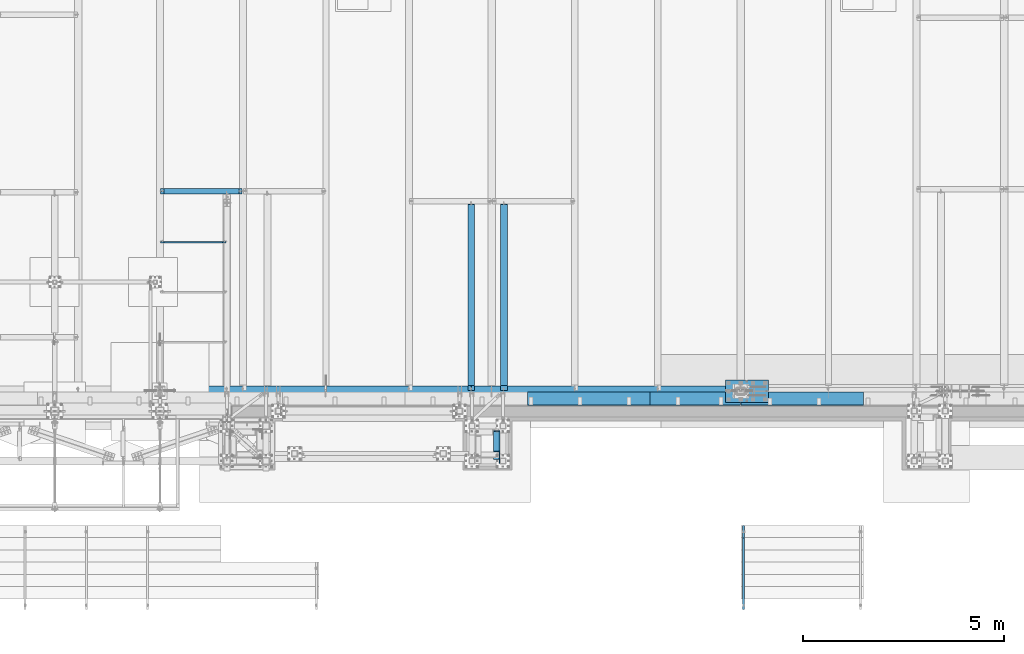
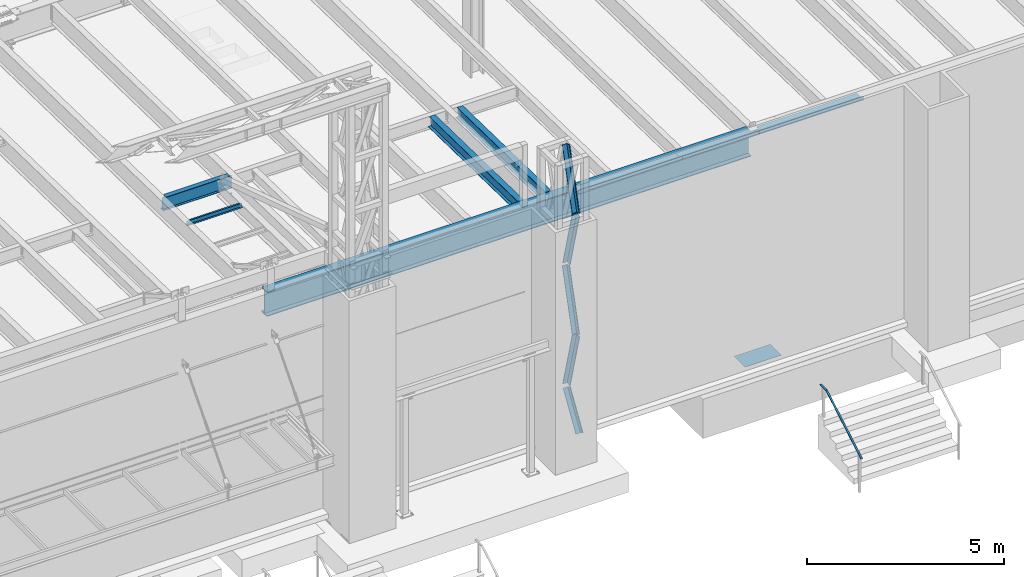
# One storey, part 1065 of 1763: 10 beams, 5 members, 9 elements without a shape of their own.
"""IFC2X3 building model written with IfcOpenShell, lengths in millimetres."""

from ifc_helpers import new_model, si_unit, frame, origin_with_axes, place, context, subcontext, project, spatial, faceted_brep, material, type_object, element, aggregate, save


model = new_model("IFC2X3")

# Units and contexts
model_context = context("Model", 3, precision=1e-05, world=origin_with_axes())
body_context = subcontext(model_context, "Body", "Model", "MODEL_VIEW")
ifc_project = project(units=[si_unit("LENGTHUNIT", "METRE", prefix="MILLI"), si_unit("AREAUNIT", "SQUARE_METRE"), si_unit("VOLUMEUNIT", "CUBIC_METRE"), si_unit("MASSUNIT", "GRAM", prefix="KILO"), si_unit("TIMEUNIT", "SECOND"), si_unit("PLANEANGLEUNIT", "RADIAN"), si_unit("SOLIDANGLEUNIT", "STERADIAN"), si_unit("THERMODYNAMICTEMPERATUREUNIT", "DEGREE_CELSIUS"), si_unit("LUMINOUSINTENSITYUNIT", "LUMEN")], contexts=[model_context])

# Site, building, storey
site_placement = place(None, origin_with_axes())
site = spatial("IfcSite", under=ifc_project, at=site_placement, CompositionType="ELEMENT")
building_placement = place(site_placement, origin_with_axes())
building = spatial("IfcBuilding", under=site, at=building_placement, Name="Undefined", CompositionType="ELEMENT")
storey_placement = place(building_placement, origin_with_axes())
storey = spatial("IfcBuildingStorey", under=building, at=storey_placement, Name="Undefined", CompositionType="ELEMENT", Elevation=0.0)

# Assembly, members
assembly_1_placement = place(storey_placement, origin_with_axes())
assembly_1 = element("IfcElementAssembly", 1, at=assembly_1_placement, inside=storey, Name="FRAME", AssemblyPlace="NOTDEFINED", PredefinedType="RIGID_FRAME")
ifc_material_1 = material(Name="STEEL/A36")
member_type = type_object("IfcMemberType", Name="L6X6X7/8", PredefinedType="NOTDEFINED")
member_1_placement = place(assembly_1_placement, frame((-41020.4383006159, -14787.0004435878, 10758.1513109615), z_axis=(-1.0, 0.0, 0.0), x_axis=(0.0, -0.25744609400632, 0.966292662023721)))
member_1 = element("IfcMember", 2, at=member_1_placement, type_object=member_type, material=ifc_material_1, Name="V. BRACE", ObjectType="L6X6X7/8", context=body_context, shape_type="Brep", body=[
    faceted_brep([(9.09494701772928e-13, -76.2000000000007, -76.2000000000844), (9.09494701772928e-13, 76.2000000000007, -76.2000000000844), (1868.75344729561, 76.1999999999971, -76.1999999992731), (1868.75344729561, -76.1999999999971, -76.1999999992731), (1.81898940354586e-12, -76.2000000000007, -53.9750000000604), (1.81898940354586e-12, 53.9750000000004, -53.9750000000604), (0.0, 53.9750000000004, 76.2000000000771), (0.0, 76.2000000000007, 76.2000000000771), (1868.7534472956, -76.1999999999971, -53.9749999992673), (1868.7534472956, 53.9750000000058, -53.9749999992673), (1868.75344729555, 53.9750000000058, 76.2000000007865), (1868.75344729555, 76.1999999999971, 76.2000000007865)], [[[0, 1, 2, 3]], [[0, 4, 5, 6, 7, 1]], [[5, 4, 8, 9]], [[6, 5, 9, 10]], [[7, 6, 10, 11]], [[1, 7, 11, 2]], [[10, 9, 8, 3, 2, 11]], [[4, 0, 3, 8]]]),
])
member_2_placement = place(assembly_1_placement, frame((-41020.4383006193, -15268.2601858948, 12613.6591825804), z_axis=(-1.0, 0.0, 0.0), x_axis=(0.0, 0.266418265103921, 0.963857514375967)))
member_2 = element("IfcMember", 3, at=member_2_placement, type_object=member_type, material=ifc_material_1, Name="V. BRACE", ObjectType="L6X6X7/8", context=body_context, shape_type="Brep", body=[
    faceted_brep([(9.09494701772928e-13, -76.2000000000007, -76.2000000000844), (9.09494701772928e-13, 76.2000000000007, -76.2000000000844), (1892.74960718638, 76.1999999999971, -76.2000000004191), (1892.74960718638, -76.1999999999971, -76.2000000004191), (1.81898940354586e-12, -76.2000000000007, -53.9750000000604), (1.81898940354586e-12, 53.9750000000004, -53.9750000000604), (0.0, 53.9750000000004, 76.2000000000771), (0.0, 76.2000000000007, 76.2000000000771), (1892.74960718638, -76.1999999999971, -53.9750000004096), (1892.74960718638, 53.9750000000058, -53.9750000004096), (1892.74960718641, 53.9750000000058, 76.1999999996406), (1892.74960718641, 76.1999999999971, 76.1999999996406)], [[[0, 1, 2, 3]], [[0, 4, 5, 6, 7, 1]], [[5, 4, 8, 9]], [[6, 5, 9, 10]], [[7, 6, 10, 11]], [[1, 7, 11, 2]], [[10, 9, 8, 3, 2, 11]], [[4, 0, 3, 8]]]),
])
member_3_placement = place(assembly_1_placement, frame((-41020.4383006091, -14787.0004435878, 7010.06381096154), z_axis=(-1.0, 0.0, 0.0), x_axis=(0.0, -0.25744609400632, 0.966292662023721)))
member_3 = element("IfcMember", 4, at=member_3_placement, type_object=member_type, material=ifc_material_1, Name="V. BRACE", ObjectType="L6X6X7/8", context=body_context, shape_type="Brep", body=[
    faceted_brep([(9.09494701772928e-13, -76.2000000000007, -76.2000000000844), (9.09494701772928e-13, 76.2000000000007, -76.2000000000844), (1868.75344729561, 76.1999999999971, -76.1999999992731), (1868.75344729561, -76.1999999999971, -76.1999999992731), (1.81898940354586e-12, -76.2000000000007, -53.9750000000604), (1.81898940354586e-12, 53.9750000000004, -53.9750000000604), (0.0, 53.9750000000004, 76.2000000000771), (0.0, 76.2000000000007, 76.2000000000771), (1868.7534472956, -76.1999999999971, -53.9749999992673), (1868.7534472956, 53.9750000000058, -53.9749999992673), (1868.75344729555, 53.9750000000058, 76.2000000007865), (1868.75344729555, 76.1999999999971, 76.2000000007865)], [[[0, 1, 2, 3]], [[0, 4, 5, 6, 7, 1]], [[5, 4, 8, 9]], [[6, 5, 9, 10]], [[7, 6, 10, 11]], [[1, 7, 11, 2]], [[10, 9, 8, 3, 2, 11]], [[4, 0, 3, 8]]]),
])
member_4_placement = place(assembly_1_placement, frame((-41020.4384470911, -15452.6556024423, 5905.50000000773), z_axis=(-1.0, 0.0, 0.0), x_axis=(1.18999999498545e-07, 0.53163042301006, 0.846976442016028)))
member_4 = element("IfcMember", 5, at=member_4_placement, type_object=member_type, material=ifc_material_1, Name="V. BRACE", ObjectType="L6X6X7/8", context=body_context, shape_type="Brep", body=[
    faceted_brep([(9.09494701772928e-13, -76.2000000000007, -76.2000000000844), (9.09494701772928e-13, 76.2000000000007, -76.2000000000844), (1228.13053531922, 76.1999999928375, -76.2000000008793), (1228.1305353191, -76.2000000071712, -76.2000000007974), (1.81898940354586e-12, -76.2000000000007, -53.9750000000604), (1.81898940354586e-12, 53.9750000000004, -53.9750000000604), (0.0, 53.9750000000004, 76.2000000000771), (0.0, 76.2000000000007, 76.2000000000771), (1228.13053531911, -76.2000000070693, -53.9750000008135), (1228.13053531921, 53.9749999929481, -53.9750000008862), (1228.13053531927, 53.9749999934866, 76.1999999990185), (1228.13053531929, 76.1999999934924, 76.1999999990057)], [[[0, 1, 2, 3]], [[0, 4, 5, 6, 7, 1]], [[5, 4, 8, 9]], [[6, 5, 9, 10]], [[7, 6, 10, 11]], [[1, 7, 11, 2]], [[10, 9, 8, 3, 2, 11]], [[4, 0, 3, 8]]]),
])
member_5_placement = place(assembly_1_placement, frame((-41020.4383006125, -15268.2601858948, 8865.57168258042), z_axis=(-1.0, 0.0, 0.0), x_axis=(0.0, 0.266418265103921, 0.963857514375967)))
member_5 = element("IfcMember", 6, at=member_5_placement, type_object=member_type, material=ifc_material_1, Name="V. BRACE", ObjectType="L6X6X7/8", context=body_context, shape_type="Brep", body=[
    faceted_brep([(9.09494701772928e-13, -76.2000000000007, -76.2000000000844), (9.09494701772928e-13, 76.2000000000007, -76.2000000000844), (1892.74960718638, 76.1999999999971, -76.2000000004191), (1892.74960718638, -76.1999999999971, -76.2000000004191), (1.81898940354586e-12, -76.2000000000007, -53.9750000000604), (1.81898940354586e-12, 53.9750000000004, -53.9750000000604), (0.0, 53.9750000000004, 76.2000000000771), (0.0, 76.2000000000007, 76.2000000000771), (1892.74960718638, -76.1999999999971, -53.9750000004096), (1892.74960718638, 53.9750000000058, -53.9750000004096), (1892.74960718641, 53.9750000000058, 76.1999999996406), (1892.74960718641, 76.1999999999971, 76.1999999996406)], [[[0, 1, 2, 3]], [[0, 4, 5, 6, 7, 1]], [[5, 4, 8, 9]], [[6, 5, 9, 10]], [[7, 6, 10, 11]], [[1, 7, 11, 2]], [[10, 9, 8, 3, 2, 11]], [[4, 0, 3, 8]]]),
])
aggregate(assembly_1, [member_1, member_2, member_3, member_4, member_5])

# Assembly, beam
assembly_2_placement = place(storey_placement, origin_with_axes())
assembly_2 = element("IfcElementAssembly", 7, at=assembly_2_placement, inside=storey, Name="CHANNEL", AssemblyPlace="NOTDEFINED", PredefinedType="RIGID_FRAME")
beam_type_1 = type_object("IfcBeamType", Name="C6X8.2", PredefinedType="NOTDEFINED")
beam_1_placement = place(assembly_2_placement, frame((-49402.4372736983, -10007.1940204662, 12050.4660879227), z_axis=(0.0, 0.0, 1.0), x_axis=(1.0, 0.0, 0.0)))
beam_1 = element("IfcBeam", 8, at=beam_1_placement, type_object=beam_type_1, material=ifc_material_1, Name="CHANNEL", ObjectType="C6X8.2", context=body_context, shape_type="Brep", body=[
    faceted_brep([(87.3125001907392, 19.0499999999993, 50.8000000015782), (87.3125001907392, 23.8125, 50.8000000015782), (17.4624999999942, 23.8125, 50.8000000015782), (17.4624999999942, 19.0499999999993, 50.8000000015782), (92.1725797087856, 19.0499999999993, 51.7667299241657), (92.1725797087856, 23.8125, 51.7667299241657), (96.2927561769393, 19.0499999999993, 54.5197438246432), (96.2927561769393, 23.8125, 54.5197438246432), (99.0457700774132, 19.0499999999993, 58.6399202927969), (99.0457700774132, 23.8125, 58.6399202927969), (100.012500000004, 19.0499999999993, 63.4999998108433), (100.012500000004, 23.8125, 63.4999998108433), (100.012500000004, -23.8125, 76.2000000000007), (100.012500000004, 23.8125, 76.2000000000007), (100.012500000004, 19.0499999999993, 65.0887700000003), (100.012500000004, -23.8125, 72.2296624999999), (17.4624999999942, 19.0499999999993, -65.0887700000003), (17.4624999999942, -23.8125, -72.2296624999999), (1648.61752778026, -23.8125, -72.2296624999999), (1648.61752778026, 19.0499999999993, -65.0887700000003), (17.4624999999942, -23.8125, -76.2000000000007), (1648.61752778026, -23.8125, -76.2000000000007), (17.4624999999942, 23.8125, -76.2000000000007), (1648.61752778026, 23.8125, -76.2000000000007), (1648.61752778026, 23.8125, 50.7999999979074), (1648.61752778026, 19.0499999999993, 50.7999999979074), (1572.41752758952, 23.8125, 50.7999999979074), (1572.41752758952, 19.0499999999993, 50.7999999979074), (1567.55744807148, 23.8125, 51.766729920495), (1567.55744807148, 19.0499999999993, 51.766729920495), (1563.43727160332, 23.8125, 54.5197438209725), (1563.43727160332, 19.0499999999993, 54.5197438209725), (1560.68425770285, 23.8125, 58.6399202891262), (1560.68425770285, 19.0499999999993, 58.6399202891262), (1559.71752778026, 23.8125, 63.4999998071726), (1559.71752778026, 19.0499999999993, 63.4999998071726), (1559.71752778026, -23.8125, 76.2000000000007), (1559.71752778026, -23.8125, 72.2296624999999), (1559.71752778026, 19.0499999999993, 65.0887700000003), (1559.71752778026, 23.8125, 76.2000000000007)], [[[0, 1, 2, 3]], [[4, 5, 1, 0]], [[6, 7, 5, 4]], [[8, 9, 7, 6]], [[10, 11, 9, 8]], [[12, 13, 11, 10, 14, 15]], [[16, 17, 18, 19]], [[17, 20, 21, 18]], [[20, 22, 23, 21]], [[19, 18, 21, 23, 24, 25]], [[25, 24, 26, 27]], [[27, 26, 28, 29]], [[29, 28, 30, 31]], [[31, 30, 32, 33]], [[33, 32, 34, 35]], [[36, 37, 38, 35, 34, 39]], [[37, 36, 12, 15]], [[38, 37, 15, 14]], [[8, 6, 4, 0, 3, 16, 19, 25, 27, 29, 31, 33, 35, 38, 14, 10]], [[22, 20, 17, 16, 3, 2]], [[39, 34, 32, 30, 28, 26, 24, 23, 22, 2, 1, 5, 7, 9, 11, 13]], [[36, 39, 13, 12]]]),
])
aggregate(assembly_2, [beam_1])

assembly_3_placement = place(storey_placement, origin_with_axes())
assembly_3 = element("IfcElementAssembly", 9, at=assembly_3_placement, inside=storey, Name="BEAM", AssemblyPlace="NOTDEFINED", PredefinedType="RIGID_FRAME")
ifc_material_2 = material(Name="STEEL/A992")
beam_type_2 = type_object("IfcBeamType", Name="W14X30", PredefinedType="NOTDEFINED")
beam_2_placement = place(assembly_3_placement, frame((-40842.6384959181, -13719.5915461759, 12028.5241025932), z_axis=(0.0, 0.0203812129899107, 0.999792281505043), x_axis=(0.0, 0.999792281505044, -0.0203812129898941)))
beam_2 = element("IfcBeam", 10, at=beam_2_placement, type_object=beam_type_2, material=ifc_material_2, Name="BEAM", ObjectType="W14X30", context=body_context, shape_type="Brep", body=[
    faceted_brep([(4643.22007065006, -85.7249999999985, 176.212500002597), (4643.22007065007, -85.7249999999985, 166.68750000259), (4643.22007065007, -3.17500000000291, 166.68750000259), (4643.22007065008, -3.17500000000291, 156.902501503215), (4643.22007065008, 3.17500000000291, 156.902501503215), (4643.22007065007, 3.17500000000291, 166.68750000259), (4643.22007065007, 85.7249999999985, 166.68750000259), (4643.22007065006, 85.7249999999985, 176.212500002597), (4644.18680057267, -3.17500000000291, 152.042421985161), (4644.18680057267, 3.17500000000291, 152.042421985161), (4646.93981447315, -3.17500000000291, 147.922245517004), (4646.93981447315, 3.17500000000291, 147.922245517004), (4651.05999094131, -3.17500000000291, 145.169231616524), (4651.05999094131, 3.17500000000291, 145.169231616524), (4655.92007045936, -3.17500000000291, 144.202501693939), (4655.92007045936, 3.17500000000291, 144.202501693939), (4710.13043812963, -3.17500000000291, 144.202501693968), (4710.13043812963, 3.17500000000291, 144.202501693968), (151.234261463611, -85.7249999999985, 176.212500000163), (151.234261463611, 85.7249999999985, 176.212500000163), (151.234261463616, 85.7249999999985, 166.687500000158), (151.234261463616, 3.17500000000291, 166.687500000158), (151.234261463636, 3.17500000000291, 131.502497673198), (151.234261463636, -3.17500000000291, 131.502497673198), (151.234261463616, -3.17500000000291, 166.687500000158), (151.234261463616, -85.7249999999985, 166.687500000158), (150.267531541049, 3.17500000000291, 126.642418155145), (150.267531541049, -3.17500000000291, 126.642418155145), (147.514517640569, 3.17500000000291, 122.522241686986), (147.514517640569, -3.17500000000291, 122.522241686986), (143.394341172412, 3.17500000000291, 119.769227786501), (143.394341172412, -3.17500000000291, 119.769227786501), (138.534261654358, 3.17500000000291, 118.802497863908), (138.534261654358, -3.17500000000291, 118.802497863908), (21.8124193891163, 3.17500000000291, 118.802497863844), (21.8124193891163, -3.17500000000291, 118.802497863844), (27.6322607307538, 3.17500000000291, -166.68750000006), (27.6322607307538, 85.7249999999985, -166.68750000006), (27.8264321174702, 85.7249999999985, -176.212500000065), (27.8264321174702, -85.7249999999985, -176.212500000065), (27.6322607307538, -85.7249999999985, -166.68750000006), (27.6322607307538, -3.17500000000291, -166.68750000006), (4716.46806991387, 3.17500000000291, -166.687499997519), (4716.46806991387, 85.7249999999985, -166.687499997519), (4716.66224130059, 85.7249999999985, -176.212499997522), (4716.66224130059, -85.7249999999985, -176.212499997522), (4716.46806991387, -85.7249999999985, -166.687499997519), (4716.46806991387, -3.17500000000291, -166.687499997519)], [[[0, 1, 2, 3, 4, 5, 6, 7]], [[8, 9, 4, 3]], [[10, 11, 9, 8]], [[12, 13, 11, 10]], [[14, 15, 13, 12]], [[16, 17, 15, 14]], [[18, 19, 20, 21, 22, 23, 24, 25]], [[23, 22, 26, 27]], [[27, 26, 28, 29]], [[29, 28, 30, 31]], [[31, 30, 32, 33]], [[33, 32, 34, 35]], [[36, 37, 38, 39, 40, 41, 35, 34]], [[37, 36, 42, 43]], [[38, 37, 43, 44]], [[39, 38, 44, 45]], [[40, 39, 45, 46]], [[41, 40, 46, 47]], [[12, 10, 8, 3, 2, 24, 23, 27, 29, 31, 33, 35, 41, 47, 16, 14]], [[25, 24, 2, 1]], [[18, 25, 1, 0]], [[19, 18, 0, 7]], [[20, 19, 7, 6]], [[21, 20, 6, 5]], [[42, 36, 34, 32, 30, 28, 26, 22, 21, 5, 4, 9, 11, 13, 15, 17]], [[47, 46, 45, 44, 43, 42, 17, 16]]]),
])
aggregate(assembly_3, [beam_2])

assembly_4_placement = place(storey_placement, origin_with_axes())
assembly_4 = element("IfcElementAssembly", 11, at=assembly_4_placement, inside=storey, Name="BEAM", AssemblyPlace="NOTDEFINED", PredefinedType="RIGID_FRAME")
beam_3_placement = place(assembly_4_placement, frame((-41655.4384959181, -13719.56444169, 12028.523552142), z_axis=(0.0, 0.0202273960059865, 0.999795405295912), x_axis=(0.0, 0.999795405295912, -0.0202273960060005)))
beam_3 = element("IfcBeam", 12, at=beam_3_placement, type_object=beam_type_2, material=ifc_material_2, Name="BEAM", ObjectType="W14X30", context=body_context, shape_type="Brep", body=[
    faceted_brep([(138.507075903297, -3.17500000000291, 118.802497863813), (138.507075903297, 3.17500000000291, 118.802497863813), (21.8035187866535, 3.17500000000291, 118.802497863793), (21.8035187866535, -3.17500000000291, 118.802497863793), (143.367155421345, -3.17500000000291, 119.769227786404), (143.367155421345, 3.17500000000291, 119.769227786404), (147.487331889499, -3.17500000000291, 122.522241686884), (147.487331889499, 3.17500000000291, 122.522241686884), (150.240345789978, -3.17500000000291, 126.642418155039), (150.240345789978, 3.17500000000291, 126.642418155039), (151.207075712564, -3.17500000000291, 131.502497673087), (151.207075712564, 3.17500000000291, 131.502497673087), (151.207075712555, -85.7249999999985, 176.212500000051), (151.207075712555, 85.7249999999985, 176.212500000051), (151.207075712557, 85.7249999999985, 166.687500000049), (151.207075712557, 3.17500000000291, 166.687500000049), (151.207075712557, -3.17500000000291, 166.687500000049), (151.207075712557, -85.7249999999985, 166.687500000049), (27.5794197479408, -3.17500000000291, -166.687500000011), (27.5794197479408, -85.7249999999985, -166.687500000011), (4716.40057898811, -85.7249999999985, -166.687499999094), (4716.40057898811, -3.17500000000291, -166.687499999094), (27.772125121397, -85.7249999999985, -176.212500000012), (4716.59328436156, -85.7249999999985, -176.212499999096), (27.772125121397, 85.7249999999985, -176.212500000012), (4716.59328436156, 85.7249999999985, -176.212499999096), (27.5794197479408, 85.7249999999985, -166.687500000011), (4716.40057898811, 85.7249999999985, -166.687499999094), (27.5794197479408, 3.17500000000291, -166.687500000011), (4716.40057898811, 3.17500000000291, -166.687499999094), (4710.11079695367, 3.17500000000291, 144.202501684027), (4710.11079695367, -3.17500000000291, 144.202501684027), (4655.87823476279, 3.17500000000291, 144.202501684016), (4655.87823476279, -3.17500000000291, 144.202501684016), (4651.01815524475, 3.17500000000291, 145.169231606602), (4651.01815524475, -3.17500000000291, 145.169231606602), (4646.89797877659, 3.17500000000291, 147.922245507081), (4646.89797877659, -3.17500000000291, 147.922245507081), (4644.14496487611, 3.17500000000291, 152.042421975237), (4644.14496487611, -3.17500000000291, 152.042421975237), (4643.17823495352, 3.17500000000291, 156.902501493283), (4643.17823495352, -3.17500000000291, 156.902501493283), (4643.17823495352, -85.7249999999985, 176.212500000929), (4643.17823495352, -85.7249999999985, 166.687500000928), (4643.17823495352, -3.17500000000291, 166.687500000928), (4643.17823495352, 3.17500000000291, 166.687500000928), (4643.17823495352, 85.7249999999985, 166.687500000928), (4643.17823495352, 85.7249999999985, 176.212500000929)], [[[0, 1, 2, 3]], [[4, 5, 1, 0]], [[6, 7, 5, 4]], [[8, 9, 7, 6]], [[10, 11, 9, 8]], [[12, 13, 14, 15, 11, 10, 16, 17]], [[18, 19, 20, 21]], [[19, 22, 23, 20]], [[22, 24, 25, 23]], [[24, 26, 27, 25]], [[26, 28, 29, 27]], [[21, 20, 23, 25, 27, 29, 30, 31]], [[31, 30, 32, 33]], [[33, 32, 34, 35]], [[35, 34, 36, 37]], [[37, 36, 38, 39]], [[39, 38, 40, 41]], [[42, 43, 44, 41, 40, 45, 46, 47]], [[43, 42, 12, 17]], [[44, 43, 17, 16]], [[8, 6, 4, 0, 3, 18, 21, 31, 33, 35, 37, 39, 41, 44, 16, 10]], [[28, 26, 24, 22, 19, 18, 3, 2]], [[45, 40, 38, 36, 34, 32, 30, 29, 28, 2, 1, 5, 7, 9, 11, 15]], [[46, 45, 15, 14]], [[47, 46, 14, 13]], [[42, 47, 13, 12]]]),
])
aggregate(assembly_4, [beam_3])

assembly_5_placement = place(storey_placement, origin_with_axes())
assembly_5 = element("IfcElementAssembly", 13, at=assembly_5_placement, inside=storey, Name="BEAM", AssemblyPlace="NOTDEFINED", PredefinedType="RIGID_FRAME")
beam_type_3 = type_object("IfcBeamType", Name="W16X26", PredefinedType="NOTDEFINED")
beam_4_placement = place(assembly_5_placement, frame((-49402.4372736983, -8739.17923577986, 11900.6299693336), z_axis=(0.0, 0.0, 1.0), x_axis=(1.0, 0.0, 0.0)))
beam_4 = element("IfcBeam", 14, at=beam_4_placement, type_object=beam_type_3, material=ifc_material_2, Name="BEAM", ObjectType="W16X26", context=body_context, shape_type="Brep", body=[
    faceted_brep([(87.3125001907465, -3.17499999999927, 168.01500167877), (87.3125001907465, 3.17499999999927, 168.01500167877), (17.4625000000087, 3.17499999999927, 168.01500167877), (17.4625000000087, -3.17499999999927, 168.01500167877), (92.1725797087929, -3.17499999999927, 168.981731601358), (92.1725797087929, 3.17499999999927, 168.981731601358), (96.2927561769466, -3.17499999999927, 171.734745501835), (96.2927561769466, 3.17499999999927, 171.734745501835), (99.0457700774205, -3.17499999999927, 175.854921969989), (99.0457700774205, 3.17499999999927, 175.854921969989), (100.012500000012, -3.17499999999927, 180.715001488035), (100.012500000012, 3.17499999999927, 180.715001488035), (100.012500000012, -69.8500000000004, 200.025), (100.012500000012, 69.8500000000004, 200.025), (100.012500000012, 69.8500000000004, 190.5), (100.012500000012, 3.17499999999927, 190.5), (100.012500000012, -3.17499999999927, 190.5), (100.012500000012, -69.8500000000004, 190.5), (17.4625000000087, -3.17499999999927, -190.5), (17.4625000000087, -69.8500000000004, -190.5), (2047.19464285716, -69.8500000000004, -190.5), (2047.19464285716, -3.17499999999927, -190.5), (17.4625000000087, -69.8500000000004, -200.025), (2047.19464285716, -69.8500000000004, -200.025), (17.4625000000087, 69.8500000000004, -200.025), (2047.19464285716, 69.8500000000004, -200.025), (17.4625000000087, 69.8500000000004, -190.5), (2047.19464285716, 69.8500000000004, -190.5), (17.4625000000087, 3.17499999999927, -190.5), (2047.19464285716, 3.17499999999927, -190.5), (2047.19464285716, 3.17499999999927, 168.015001678501), (2047.19464285716, -3.17499999999927, 168.015001678501), (1977.34464266642, 3.17499999999927, 168.015001678501), (1977.34464266642, -3.17499999999927, 168.015001678501), (1972.48456314838, 3.17499999999927, 168.981731601089), (1972.48456314838, -3.17499999999927, 168.981731601089), (1968.36438668022, 3.17499999999927, 171.734745501566), (1968.36438668022, -3.17499999999927, 171.734745501566), (1965.61137277975, 3.17499999999927, 175.85492196972), (1965.61137277975, -3.17499999999927, 175.85492196972), (1964.64464285716, 3.17499999999927, 180.715001487766), (1964.64464285716, -3.17499999999927, 180.715001487766), (1964.64464285716, -69.8500000000004, 200.025), (1964.64464285716, -69.8500000000004, 190.5), (1964.64464285716, -3.17499999999927, 190.5), (1964.64464285716, 3.17499999999927, 190.5), (1964.64464285716, 69.8500000000004, 190.5), (1964.64464285716, 69.8500000000004, 200.025)], [[[0, 1, 2, 3]], [[4, 5, 1, 0]], [[6, 7, 5, 4]], [[8, 9, 7, 6]], [[10, 11, 9, 8]], [[12, 13, 14, 15, 11, 10, 16, 17]], [[18, 19, 20, 21]], [[19, 22, 23, 20]], [[22, 24, 25, 23]], [[24, 26, 27, 25]], [[26, 28, 29, 27]], [[21, 20, 23, 25, 27, 29, 30, 31]], [[31, 30, 32, 33]], [[33, 32, 34, 35]], [[35, 34, 36, 37]], [[37, 36, 38, 39]], [[39, 38, 40, 41]], [[42, 43, 44, 41, 40, 45, 46, 47]], [[43, 42, 12, 17]], [[44, 43, 17, 16]], [[8, 6, 4, 0, 3, 18, 21, 31, 33, 35, 37, 39, 41, 44, 16, 10]], [[28, 26, 24, 22, 19, 18, 3, 2]], [[45, 40, 38, 36, 34, 32, 30, 29, 28, 2, 1, 5, 7, 9, 11, 15]], [[46, 45, 15, 14]], [[47, 46, 14, 13]], [[42, 47, 13, 12]]]),
])
aggregate(assembly_5, [beam_4])

assembly_6_placement = place(storey_placement, origin_with_axes())
assembly_6 = element("IfcElementAssembly", 15, at=assembly_6_placement, inside=storey, Name="HANDRAIL", AssemblyPlace="NOTDEFINED", PredefinedType="RIGID_FRAME")
beam_type_4 = type_object("IfcBeamType", PredefinedType="NOTDEFINED")
beam_5_placement = place(assembly_6_placement, frame((-34879.9872736984, -19143.8249247664, 5206.50837891029), z_axis=(-1.0, 0.0, 0.0), x_axis=(0.0, 0.863778900717086, 0.503871025834967)))
beam_5 = element("IfcBeam", 16, at=beam_5_placement, type_object=beam_type_4, material=ifc_material_1, Name="HANDRAIL", context=body_context, shape_type="Brep", body=[
    faceted_brep([(2.91038304567337e-11, -9.52499999999418, -25.4000000000015), (2.91038304567337e-11, -9.52499999999418, 25.4000000000015), (-5.82076609134674e-11, 9.52499999999418, 25.4000000000015), (-5.82076609134674e-11, 9.52499999999418, -25.4000000000015), (2065.19938791017, 9.52504462009711, 25.4000000000015), (2065.19938791017, 9.52504462009711, -25.4000000000015), (2070.3495392473, -9.52495526862185, -25.4000000000015), (2070.3495392473, -9.52495526862185, 25.4000000000015), (2326.25483773232, 161.807390474376, 25.4000000000015), (2326.25483773232, 161.807390474376, -25.4000000000015), (2335.85358077444, 145.352402415698, 25.4000000000015), (2335.85358077444, 145.352402415698, -25.4000000000015)], [[[0, 1, 2, 3]], [[3, 2, 4, 5]], [[1, 0, 6, 7]], [[5, 4, 8, 9]], [[4, 2, 1, 7, 10, 8]], [[7, 6, 11, 10]], [[6, 0, 3, 5, 9, 11]], [[10, 11, 9, 8]]]),
])
aggregate(assembly_6, [beam_5])

# Assembly, beams
assembly_7_placement = place(storey_placement, origin_with_axes())
assembly_7 = element("IfcElementAssembly", 17, at=assembly_7_placement, inside=storey, Name="BEAM", AssemblyPlace="NOTDEFINED", PredefinedType="RIGID_FRAME")
beam_type_5 = type_object("IfcBeamType", PredefinedType="NOTDEFINED")
beam_6_placement = place(assembly_7_placement, frame((-36080.1372736984, -13728.6998186171, 12207.875), z_axis=(-1.0, 0.0, 0.0), x_axis=(0.0, -1.0, 0.0)))
beam_6 = element("IfcBeam", 18, at=beam_6_placement, type_object=beam_type_5, material=ifc_material_1, Name="BENT_PLATE", context=body_context, shape_type="Brep", body=[
    faceted_brep([(101.600181382939, -3.17499999999927, -1016.0), (101.600181382939, 3.17499999999927, -1016.0), (101.60018138293, 3.17499999999927, -1127.125), (101.60018138293, -3.17499999999927, -1127.125), (0.0, -3.17499999999927, -1016.0), (0.0, 3.17499999999927, -1016.0), (330.200016784669, 3.17499999999927, 1127.125), (0.0, 3.17499999999927, 1127.125), (0.0, -3.17499999999927, 1127.125), (336.550018310547, -3.17499999999927, 1127.125), (336.549987792969, 123.825000000001, 1127.125), (330.19998779297, 123.824998474123, 1127.125), (330.200016784669, 3.17499999999927, -1127.125), (330.19998779297, 123.824998474123, -1127.125), (336.549987792969, 123.825000000001, -1127.125), (336.550018310547, -3.17499999999927, -1127.125)], [[[0, 1, 2, 3]], [[4, 5, 1, 0]], [[6, 7, 8, 9, 10, 11]], [[12, 6, 11, 13]], [[10, 14, 13, 11]], [[9, 15, 14, 10]], [[12, 13, 14, 15, 3, 2]], [[7, 6, 12, 2, 1, 5]], [[8, 7, 5, 4]], [[15, 9, 8, 4, 0, 3]]]),
])
beam_7_placement = place(assembly_7_placement, frame((-38731.2622736984, -13728.6998186171, 12207.875), z_axis=(-1.0, 0.0, 0.0), x_axis=(0.0, -1.0, 0.0)))
beam_7 = element("IfcBeam", 19, at=beam_7_placement, type_object=beam_type_5, material=ifc_material_1, Name="BENT_PLATE", context=body_context, shape_type="Brep", body=[
    faceted_brep([(0.0, -3.17499999999927, -1523.99999999999), (0.0, -3.17499999999927, 1524.0), (0.0, 3.17499999999927, 1524.0), (0.0, 3.17499999999927, -1523.99999999999), (330.200016784669, 3.17499999999927, 1524.0), (330.200016784669, 3.17499999999927, -1524.0), (336.550018310547, -3.17499999999927, -1524.0), (336.550018310547, -3.17499999999927, 1524.0), (330.19998779297, 123.824998474123, 1524.0), (330.19998779297, 123.824998474123, -1524.0), (336.549987792969, 123.825000000001, 1524.0), (336.549987792969, 123.825000000001, -1524.0)], [[[0, 1, 2, 3]], [[3, 2, 4, 5]], [[1, 0, 6, 7]], [[5, 4, 8, 9]], [[4, 2, 1, 7, 10, 8]], [[7, 6, 11, 10]], [[6, 0, 3, 5, 9, 11]], [[10, 11, 9, 8]]]),
])

# Assembly, beam
assembly_8_placement = place(storey_placement, origin_with_axes())
assembly_8 = element("IfcElementAssembly", 20, at=assembly_8_placement, inside=storey, Name="BEAM", AssemblyPlace="NOTDEFINED", PredefinedType="RIGID_FRAME")
beam_8_placement = place(assembly_8_placement, frame((-33422.6622736984, -13728.6998186171, 12207.875), z_axis=(-1.0, 0.0, 0.0), x_axis=(0.0, -1.0, 0.0)))
beam_8 = element("IfcBeam", 21, at=beam_8_placement, type_object=beam_type_5, material=ifc_material_1, Name="BENT_PLATE", context=body_context, shape_type="Brep", body=[
    faceted_brep([(101.600186157239, -3.17499999999927, 1412.875), (101.600186157239, 3.17499999999927, 1412.875), (0.0, 3.17499999999927, 1412.875), (0.0, -3.17499999999927, 1412.875), (101.600186157239, -3.17499999999927, 1524.0), (101.600186157239, 3.17499999999927, 1524.0), (336.550018310547, -3.17499999999927, -1524.0), (0.0, -3.17499999999927, -1523.99999999999), (0.0, 3.17499999999927, -1523.99999999999), (330.200016784669, 3.17499999999927, -1524.0), (330.19998779297, 123.824998474123, -1524.0), (336.549987792969, 123.825000000001, -1524.0), (330.200016784669, 3.17499999999927, 1524.0), (330.19998779297, 123.824998474123, 1524.0), (336.549987792969, 123.825000000001, 1524.0), (336.550018310547, -3.17499999999927, 1524.0)], [[[0, 1, 2, 3]], [[4, 5, 1, 0]], [[6, 7, 8, 9, 10, 11]], [[9, 12, 13, 10]], [[14, 11, 10, 13]], [[15, 6, 11, 14]], [[3, 7, 6, 15, 4, 0]], [[8, 7, 3, 2]], [[12, 9, 8, 2, 1, 5]], [[15, 14, 13, 12, 5, 4]]]),
])
aggregate(assembly_8, [beam_8])

assembly_9_placement = place(storey_placement, origin_with_axes())
assembly_9 = element("IfcElementAssembly", 22, at=assembly_9_placement, inside=storey, Name="TEMPLATE", AssemblyPlace="NOTDEFINED", PredefinedType="RIGID_FRAME")
beam_type_6 = type_object("IfcBeamType", PredefinedType="NOTDEFINED")
beam_9_placement = place(assembly_9_placement, frame((-34797.4372736983, -13995.4, 5083.175), z_axis=(-1.0, 0.0, 0.0), x_axis=(0.0, 1.0, 0.0)))
beam_9 = element("IfcBeam", 23, at=beam_9_placement, type_object=beam_type_6, material=ifc_material_1, Name="TEMPLATE", context=body_context, shape_type="Brep", body=[
    faceted_brep([(0.0, 3.17500000000018, -533.399999999994), (0.0, 3.17500000000018, 533.399999999994), (558.799999999999, 3.17500000000018, 533.399999999994), (558.799999999999, 3.17500000000018, -533.399999999994), (0.0, -3.17500000000018, 533.399999999994), (558.799999999999, -3.17500000000018, 533.399999999994), (0.0, -3.17500000000018, -533.399999999994), (558.799999999999, -3.17500000000018, -533.399999999994)], [[[0, 1, 2, 3]], [[1, 4, 5, 2]], [[4, 6, 7, 5]], [[6, 0, 3, 7]], [[5, 7, 3, 2]], [[6, 4, 1, 0]]]),
])
aggregate(assembly_9, [beam_9])

# Beam
beam_type_7 = type_object("IfcBeamType", Name="W30X132", PredefinedType="NOTDEFINED")
beam_10_placement = place(assembly_7_placement, frame((-49402.4372736983, -13715.9998186171, 11820.525), z_axis=(0.0, 0.0, 1.0), x_axis=(1.0, 0.0, 0.0)))
beam_10 = element("IfcBeam", 24, at=beam_10_placement, type_object=beam_type_7, material=ifc_material_2, Name="BEAM", ObjectType="W30X132", context=body_context, shape_type="Brep", body=[
    faceted_brep([(139.699999999997, -133.35, -358.775), (139.699999999997, -133.35, -384.174999999999), (14338.3, -133.35, -384.174999999999), (14338.3, -133.35, -358.775), (139.699999999997, -7.9375, -358.775), (14338.3, -7.9375, -358.775), (139.699999999997, -7.9375, 358.775), (14338.3, -7.9375, 358.775), (139.699999999997, -133.35, 358.775), (14338.3, -133.35, 358.775), (139.699999999997, -133.35, 384.174999999999), (14338.3, -133.35, 384.174999999999), (139.699999999997, 133.35, 384.174999999999), (14338.3, 133.35, 384.174999999999), (139.699999999997, 133.35, 358.775), (14338.3, 133.35, 358.775), (139.699999999997, 7.9375, 358.775), (14338.3, 7.9375, 358.775), (139.699999999997, 7.9375, -358.775), (14338.3, 7.9375, -358.775), (139.699999999997, 133.35, -358.775), (14338.3, 133.35, -358.775), (139.699999999997, 133.35, -384.174999999999), (14338.3, 133.35, -384.174999999999)], [[[0, 1, 2, 3]], [[4, 0, 3, 5]], [[6, 4, 5, 7]], [[8, 6, 7, 9]], [[10, 8, 9, 11]], [[12, 10, 11, 13]], [[14, 12, 13, 15]], [[16, 14, 15, 17]], [[18, 16, 17, 19]], [[20, 18, 19, 21]], [[1, 0, 4, 6, 8, 10, 12, 14, 16, 18, 20, 22]], [[1, 22, 23, 2]], [[19, 17, 15, 13, 11, 9, 7, 5, 3, 2, 23, 21]], [[22, 20, 21, 23]]]),
])

aggregate(assembly_7, [beam_6, beam_7, beam_10])

save(model, "model.ifc")
